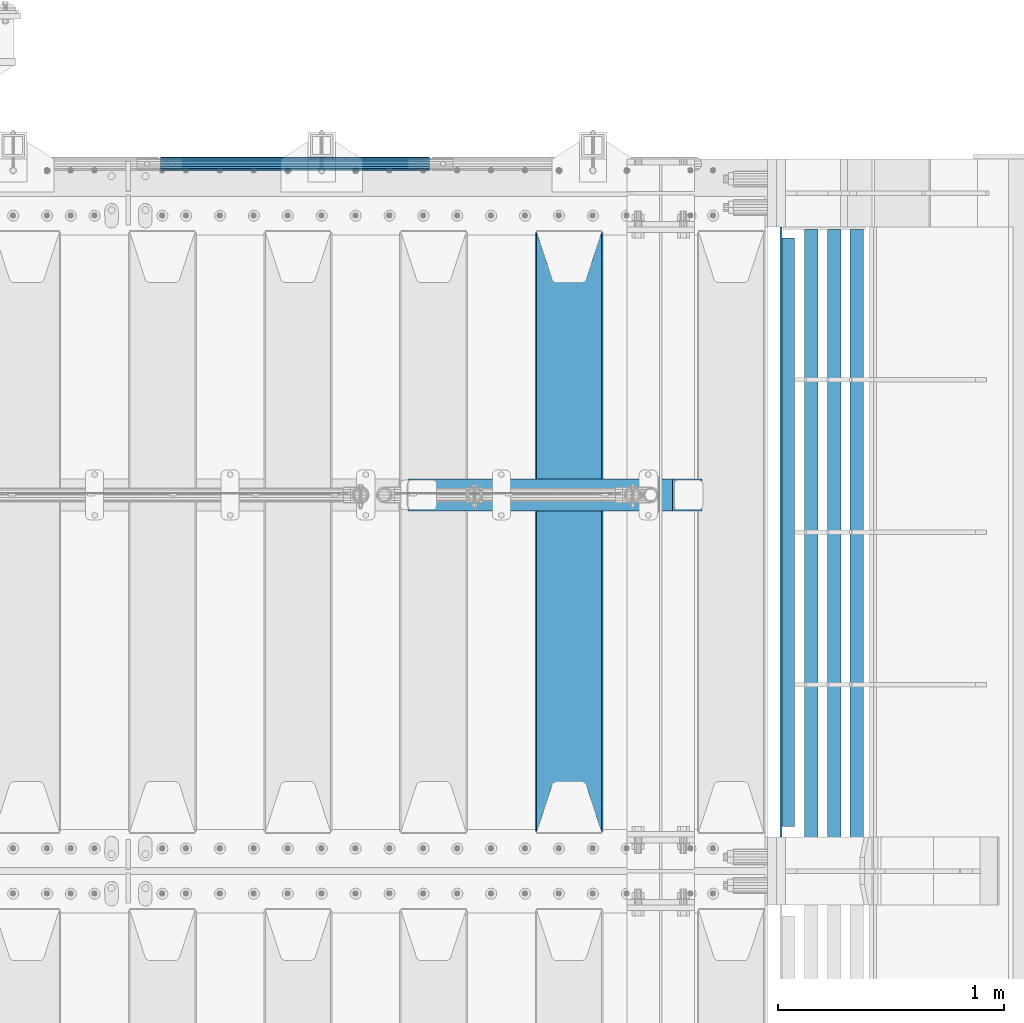
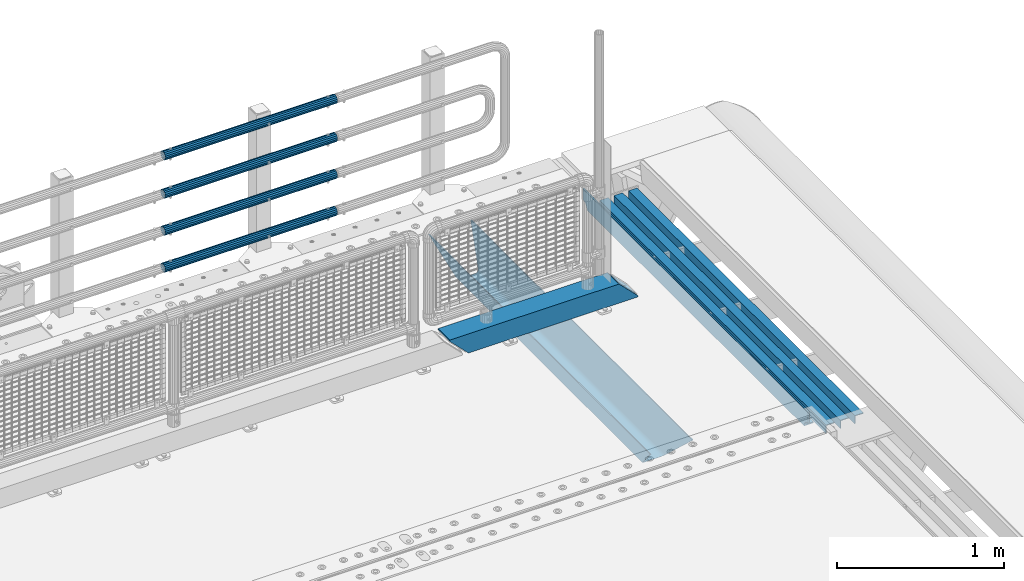
# One storey, part 102 of 193: 10 beams.
"""IFC2X3 building model written with IfcOpenShell, lengths in millimetres."""

from ifc_helpers import new_model, si_unit, frame, origin_with_axes, place, context, subcontext, project, spatial, faceted_brep, material, type_object, element, save


model = new_model("IFC2X3")

# Units and contexts
model_context = context("Model", 3, precision=1e-05, world=origin_with_axes())
body_context = subcontext(model_context, "Body", "Model", "MODEL_VIEW")
ifc_project = project(units=[si_unit("LENGTHUNIT", "METRE", prefix="MILLI"), si_unit("AREAUNIT", "SQUARE_METRE"), si_unit("VOLUMEUNIT", "CUBIC_METRE"), si_unit("MASSUNIT", "GRAM", prefix="KILO"), si_unit("TIMEUNIT", "SECOND"), si_unit("PLANEANGLEUNIT", "RADIAN"), si_unit("SOLIDANGLEUNIT", "STERADIAN"), si_unit("THERMODYNAMICTEMPERATUREUNIT", "DEGREE_CELSIUS"), si_unit("LUMINOUSINTENSITYUNIT", "LUMEN")], contexts=[model_context])

# Site, building, storey
site_placement = place(None, origin_with_axes())
site = spatial("IfcSite", under=ifc_project, at=site_placement, CompositionType="ELEMENT")
building_placement = place(site_placement, origin_with_axes())
building = spatial("IfcBuilding", under=site, at=building_placement, Name="Standard", CompositionType="ELEMENT")
storey_placement = place(building_placement, origin_with_axes())
storey = spatial("IfcBuildingStorey", under=building, at=storey_placement, Name="Undefined", CompositionType="ELEMENT", Elevation=0.0)

# Beams
ifc_material_1 = material(Name="STEEL/S355N")
beam_type_1 = type_object("IfcBeamType", PredefinedType="NOTDEFINED")
beam_1_placement = place(storey_placement, frame((-29300.0, 27175.0, -115.0), z_axis=(0.0, 0.0, 1.0), x_axis=(0.0, 1.0, 0.0)))
element("IfcBeam", 1, at=beam_1_placement, inside=storey, type_object=beam_type_1, material=ifc_material_1, context=body_context, shape_type="Brep", body=[
    faceted_brep([(0.0, 150.0, 115.0), (0.0, 143.689999999999, 115.0), (2650.00000000297, 143.689999999999, 115.0), (2650.00000000297, 150.0, 115.0), (2650.00000000297, 142.059565218398, 110.000000003094), (2650.00000000297, 148.3695652184, 110.000000003094), (2441.90079219209, -80.1103600731112, -98.0992078077845), (2437.7588105432, -77.5672621345584, -102.241189456673), (2434.06523489747, -74.4080125315522, -105.934765102404), (2430.9108609509, -70.710272125576, -109.089139048974), (2428.37322971128, -66.5649389910068, -111.626770288588), (2426.51472138055, -62.0739139532889, -113.485278619323), (2425.38102192092, -57.3475956567672, -114.618978078955), (2424.99999999988, -52.5021667386536, -115.0), (2424.99999999988, 52.5021667386536, -115.0), (2425.38102192092, 57.3475956567672, -114.618978078955), (2426.51472138055, 62.0739139532889, -113.485278619323), (2428.37322971128, 66.5649389910068, -111.626770288588), (2430.9108609509, 70.710272125576, -109.089139048974), (2434.06523489747, 74.4080125315522, -105.934765102404), (2437.7588105432, 77.5672621345584, -102.241189456673), (2441.90079219209, 80.1103600731112, -98.0992078077846), (2446.38936140512, 81.9747917625791, -93.6106385947584), (2448.2494850041, 76.2713538057251, -91.7505149957729), (2444.62967112263, 74.76777986261, -95.3703288772456), (2441.28936334127, 72.7168944282894, -98.710636658607), (2438.31067330439, 70.1691124903846, -101.689326695487), (2435.76682334748, 67.1870637758839, -104.233176652398), (2433.72034654134, 63.8440531834895, -106.279653458539), (2432.22154950042, 60.222258798236, -107.778450499454), (2431.30727574265, 56.4107117849089, -108.692724257221), (2430.99999999987, 52.5031078186876, -109.0), (2430.99999999987, -52.5031078186876, -109.0), (2431.30727574265, -56.4107117849089, -108.692724257221), (2432.22154950042, -60.222258798236, -107.778450499454), (2433.72034654134, -63.8440531834895, -106.279653458539), (2435.76682334748, -67.1870637758839, -104.233176652398), (2438.31067330439, -70.1691124903846, -101.689326695487), (2441.28936334127, -72.7168944282894, -98.7106366586071), (2444.62967112263, -74.76777986261, -95.3703288772457), (2448.2494850041, -76.2713538057251, -91.7505149957729), (2650.00000000297, -142.059565218398, 110.000000003094), (2650.00000000297, -148.3695652184, 110.000000003094), (2446.38936140512, -81.9747917625791, -93.6106385947584), (2650.00000000297, -143.689999999999, 115.0), (2650.00000000297, -150.0, 115.0), (0.0, -143.689999999999, 115.0), (0.0, -150.0, 115.0), (0.0, -148.369565218261, 110.000000002667), (203.610638597427, -81.9747917625791, -93.6106385947584), (208.099207810446, -80.1103600731112, -98.0992078077845), (212.241189459342, -77.5672621345584, -102.241189456673), (215.93476510507, -74.4080125315522, -105.934765102404), (219.089139051641, -70.710272125576, -109.089139048974), (221.626770291256, -66.5649389910068, -111.626770288588), (223.485278621989, -62.0739139532889, -113.485278619323), (224.618978081624, -57.3475956567672, -114.618978078955), (225.000000002663, -52.5021667386536, -115.0), (225.000000002663, 52.5021667386536, -115.0), (224.618978081624, 57.3475956567672, -114.618978078955), (223.485278621989, 62.0739139532889, -113.485278619323), (221.626770291256, 66.5649389910068, -111.626770288588), (219.089139051641, 70.710272125576, -109.089139048974), (215.93476510507, 74.4080125315522, -105.934765102404), (212.241189459342, 77.5672621345584, -102.241189456673), (208.099207810446, 80.1103600731112, -98.0992078077846), (203.610638597427, 81.9747917625791, -93.6106385947584), (0.0, 148.369565218261, 110.000000002667), (0.0, 142.05956521826, 110.000000002667), (201.750514998439, 76.2713538057251, -91.7505149957729), (205.370328879915, 74.76777986261, -95.3703288772456), (208.710636661275, 72.7168944282894, -98.710636658607), (211.689326698157, 70.1691124903846, -101.689326695487), (214.233176655063, 67.1870637758839, -104.233176652398), (216.279653461206, 63.8440531834895, -106.279653458539), (217.778450502123, 60.222258798236, -107.778450499454), (218.69272425989, 56.4107117849089, -108.692724257221), (219.00000000267, 52.5031078186876, -109.0), (219.00000000267, -52.5031078186876, -109.0), (218.69272425989, -56.4107117849089, -108.692724257221), (217.778450502123, -60.222258798236, -107.778450499454), (216.279653461206, -63.8440531834895, -106.279653458539), (214.233176655063, -67.1870637758839, -104.233176652398), (211.689326698157, -70.1691124903846, -101.689326695487), (208.710636661275, -72.7168944282894, -98.7106366586071), (205.370328879915, -74.76777986261, -95.3703288772457), (201.750514998439, -76.2713538057251, -91.7505149957729), (0.0, -142.05956521826, 110.000000002667)], [[[0, 1, 2, 3]], [[3, 2, 4, 5]], [[6, 7, 8, 9, 10, 11, 12, 13, 14, 15, 16, 17, 18, 19, 20, 21, 22, 5, 4, 23, 24, 25, 26, 27, 28, 29, 30, 31, 32, 33, 34, 35, 36, 37, 38, 39, 40, 41, 42, 43]], [[44, 45, 42, 41]], [[46, 47, 45, 44]], [[43, 42, 45, 47, 48, 49]], [[6, 43, 49, 50]], [[7, 6, 50, 51]], [[8, 7, 51, 52]], [[9, 8, 52, 53]], [[10, 9, 53, 54]], [[11, 10, 54, 55]], [[12, 11, 55, 56]], [[13, 12, 56, 57]], [[14, 13, 57, 58]], [[15, 14, 58, 59]], [[16, 15, 59, 60]], [[17, 16, 60, 61]], [[18, 17, 61, 62]], [[19, 18, 62, 63]], [[20, 19, 63, 64]], [[21, 20, 64, 65]], [[22, 21, 65, 66]], [[0, 3, 5, 22, 66, 67]], [[1, 0, 67, 68]], [[23, 4, 2, 1, 68, 69]], [[24, 23, 69, 70]], [[25, 24, 70, 71]], [[26, 25, 71, 72]], [[27, 26, 72, 73]], [[28, 27, 73, 74]], [[29, 28, 74, 75]], [[30, 29, 75, 76]], [[31, 30, 76, 77]], [[32, 31, 77, 78]], [[33, 32, 78, 79]], [[34, 33, 79, 80]], [[35, 34, 80, 81]], [[36, 35, 81, 82]], [[37, 36, 82, 83]], [[38, 37, 83, 84]], [[39, 38, 84, 85]], [[40, 39, 85, 86]], [[46, 44, 41, 40, 86, 87]], [[47, 46, 87, 48]], [[86, 85, 84, 83, 82, 81, 80, 79, 78, 77, 76, 75, 74, 73, 72, 71, 70, 69, 68, 67, 66, 65, 64, 63, 62, 61, 60, 59, 58, 57, 56, 55, 54, 53, 52, 51, 50, 49, 48, 87]]]),
])
ifc_material_2 = material(Name="STEEL/S355J2")
beam_type_2 = type_object("IfcBeamType", PredefinedType="NOTDEFINED")
beam_2_placement = place(storey_placement, frame((-28335.4974739935, 27150.0, -124.999999999993), z_axis=(0.0, 0.0, 1.0), x_axis=(0.0, 1.0, 0.0)))
element("IfcBeam", 2, at=beam_2_placement, inside=storey, type_object=beam_type_2, material=ifc_material_2, context=body_context, shape_type="Brep", body=[
    faceted_brep([(2700.0, 22.5, -15.0), (2684.54915028125, 22.5000000000036, -17.4471741852423), (2684.54915028125, 32.5000000000036, -17.4471741852423), (2700.0, 32.5, -15.0), (2670.61073738538, 22.5000000000036, -24.5491502812526), (2670.61073738538, 32.5000000000036, -24.5491502812526), (2659.54915028125, 22.5000000000036, -35.6107373853764), (2659.54915028125, 32.5000000000036, -35.6107373853764), (2652.44717418524, 22.5000000000036, -49.5491502812526), (2652.44717418524, 32.5000000000036, -49.5491502812526), (2651.58384440325, -32.5, -55.0), (2650.0, -32.5, -65.0), (2650.0, 32.5, -65.0), (2651.58384440325, 22.5, -55.0), (0.0, 32.5, 65.0), (0.0, 22.5, 65.0), (2700.0, 22.5, 65.0), (2700.0, 32.5, 65.0), (0.0, 32.5, -15.0), (0.0, 22.5, -15.0), (15.4508497187489, 32.5, -17.4471741852423), (15.4508497187489, 22.5, -17.4471741852423), (29.3892626146226, 32.5, -24.5491502812526), (29.3892626146226, 22.5, -24.5491502812526), (40.4508497187489, 32.5, -35.6107373853764), (40.4508497187489, 22.5, -35.6107373853764), (47.5528258147569, 32.5, -49.5491502812526), (47.5528258147569, 22.5, -49.5491502812526), (50.0, -32.5, -65.0), (48.4161555967548, -32.5, -55.0), (48.4161555967548, 22.5, -55.0), (50.0, 32.5, -65.0)], [[[0, 1, 2, 3]], [[4, 5, 2, 1]], [[6, 7, 5, 4]], [[8, 9, 7, 6]], [[10, 11, 12, 9, 8, 13]], [[14, 15, 16, 17]], [[15, 14, 18, 19]], [[19, 18, 20, 21]], [[21, 20, 22, 23]], [[23, 22, 24, 25]], [[25, 24, 26, 27]], [[28, 29, 30, 27, 26, 31]], [[30, 29, 10, 13]], [[16, 15, 19, 21, 23, 25, 27, 30, 13, 8, 6, 4, 1, 0]], [[17, 16, 0, 3]], [[5, 7, 9, 12, 31, 26, 24, 22, 20, 18, 14, 17, 3, 2]], [[28, 31, 12, 11]], [[29, 28, 11, 10]]]),
])
beam_type_3 = type_object("IfcBeamType", PredefinedType="NOTDEFINED")
for number, where, z_axis, x_axis in (
    (3, (-28028.001170099, 29839.9999004142, -209.999999999564), (0.0, 0.0, -1.0), (0.0, -1.0, 0.0)),
    (4, (-28128.001170099, 29839.9999004143, -209.999999999564), (0.0, 0.0, -1.0), (0.0, -1.0, 0.0)),
    (5, (-28228.0011700997, 29840.0000023388, -209.999999999622), (0.0, 0.0, -1.0), (0.0, -1.0, 0.0)),
):
    element("IfcBeam", number, at=place(storey_placement, frame(where, z_axis=z_axis, x_axis=x_axis)), inside=storey, type_object=beam_type_3, material=ifc_material_2, context=body_context, shape_type="Brep", body=[
        faceted_brep([(3.63797880709171e-12, 30.0000000000036, -30.0), (0.0, 30.0000000000036, 30.0), (2710.00017042502, 30.0000000000036, 30.0), (2710.00017042501, 30.0000000000036, -30.0), (0.0, 24.0000000000036, 30.0), (2710.00017042502, 24.0000000000036, 30.0), (0.0, 24.0000000000036, -24.0), (2710.00017042502, 24.0000000000036, -24.0), (3.63797880709171e-12, -29.9999999999964, -24.0), (2710.00017042502, -29.9999999999964, -24.0), (3.63797880709171e-12, -29.9999999999964, -30.0), (2710.00017042501, -29.9999999999964, -30.0)], [[[0, 1, 2, 3]], [[1, 4, 5, 2]], [[4, 6, 7, 5]], [[6, 8, 9, 7]], [[8, 10, 11, 9]], [[10, 0, 3, 11]], [[5, 7, 9, 11, 3, 2]], [[10, 8, 6, 4, 1, 0]]]),
    ])
ifc_material_3 = material()
beam_type_4 = type_object("IfcBeamType", PredefinedType="NOTDEFINED")
beam_3_placement = place(storey_placement, frame((-31107.9999999999, 30129.8499999996, 419.849999999748), z_axis=(0.0, -1.0, 0.0), x_axis=(1.0, 0.0, 0.0)))
element("IfcBeam", 6, at=beam_3_placement, inside=storey, type_object=beam_type_4, material=ifc_material_3, context=body_context, shape_type="Brep", body=[
    faceted_brep([(0.0, -26.5499999999993, 0.0), (0.0, -24.5290015881765, 10.1602451292931), (1190.0, -24.5290015881747, 10.1602451292929), (1190.0, -26.55, 0.0), (0.0, -18.7736850405017, 18.7736850405028), (1190.0, -18.7736850405028, 18.7736850405017), (0.0, -10.1602451292929, 24.5290015881747), (1190.0, -10.1602451292931, 24.5290015881765), (0.0, 0.0, 26.55), (1190.0, 0.0, 26.5499999999993), (0.0, 10.1602451292929, 24.5290015881747), (1190.0, 10.1602451292932, 24.5290015881765), (0.0, 18.7736850405017, 18.7736850405028), (1190.0, 18.7736850405029, 18.7736850405017), (0.0, 24.5290015881765, 10.1602451292931), (1190.0, 24.5290015881747, 10.1602451292929), (0.0, 26.5499999999993, 0.0), (1190.0, 26.55, 0.0), (0.0, 24.5290015881765, -10.1602451292931), (1190.0, 24.5290015881747, -10.1602451292929), (0.0, 18.7736850405017, -18.7736850405028), (1190.0, 18.7736850405028, -18.7736850405017), (0.0, 10.1602451292929, -24.5290015881747), (1190.0, 10.1602451292931, -24.5290015881765), (0.0, 0.0, -26.55), (1190.0, 0.0, -26.5499999999993), (0.0, -10.1602451292929, -24.5290015881747), (1190.0, -10.1602451292931, -24.5290015881765), (0.0, -18.7736850405017, -18.7736850405028), (1190.0, -18.7736850405028, -18.7736850405017), (0.0, -24.5290015881765, -10.1602451292931), (1190.0, -24.5290015881747, -10.1602451292929), (0.0, -30.1500000000015, 0.0), (0.0, -27.8549679052157, -11.5379054858058), (1190.0, -27.8549679052153, -11.5379054858058), (1190.0, -30.15, 0.0), (0.0, -21.3192694527752, -21.3192694527752), (1190.0, -21.3192694527744, -21.3192694527752), (0.0, -11.5379054858058, -27.8549679052157), (1190.0, -11.5379054858075, -27.8549679052157), (0.0, 0.0, -30.1500000000015), (1190.0, 0.0, -30.1500000000015), (0.0, 11.5379054858058, -27.8549679052157), (1190.0, 11.5379054858075, -27.8549679052157), (0.0, 21.3192694527752, -21.3192694527752), (1190.0, 21.3192694527744, -21.3192694527752), (0.0, 27.8549679052157, -11.5379054858058), (1190.0, 27.8549679052153, -11.5379054858058), (0.0, 30.1500000000015, 0.0), (1190.0, 30.15, 0.0), (0.0, 27.8549679052157, 11.5379054858058), (1190.0, 27.8549679052153, 11.5379054858058), (0.0, 21.3192694527752, 21.3192694527752), (1190.0, 21.3192694527744, 21.3192694527752), (0.0, 11.5379054858058, 27.8549679052157), (1190.0, 11.5379054858075, 27.8549679052157), (0.0, 0.0, 30.1500000000015), (1190.0, 0.0, 30.1500000000015), (0.0, -11.5379054858058, 27.8549679052157), (1190.0, -11.5379054858075, 27.8549679052157), (0.0, -21.3192694527752, 21.3192694527752), (1190.0, -21.3192694527744, 21.3192694527752), (0.0, -27.8549679052157, 11.5379054858058), (1190.0, -27.8549679052153, 11.5379054858058)], [[[0, 1, 2, 3]], [[1, 4, 5, 2]], [[4, 6, 7, 5]], [[6, 8, 9, 7]], [[8, 10, 11, 9]], [[10, 12, 13, 11]], [[12, 14, 15, 13]], [[14, 16, 17, 15]], [[16, 18, 19, 17]], [[18, 20, 21, 19]], [[20, 22, 23, 21]], [[22, 24, 25, 23]], [[24, 26, 27, 25]], [[26, 28, 29, 27]], [[28, 30, 31, 29]], [[30, 0, 3, 31]], [[32, 33, 34, 35]], [[33, 36, 37, 34]], [[36, 38, 39, 37]], [[38, 40, 41, 39]], [[40, 42, 43, 41]], [[42, 44, 45, 43]], [[44, 46, 47, 45]], [[46, 48, 49, 47]], [[48, 50, 51, 49]], [[50, 52, 53, 51]], [[52, 54, 55, 53]], [[54, 56, 57, 55]], [[56, 58, 59, 57]], [[58, 60, 61, 59]], [[60, 62, 63, 61]], [[62, 32, 35, 63]], [[37, 39, 41, 43, 45, 47, 49, 51, 53, 55, 57, 59, 61, 63, 35, 34], [5, 7, 9, 11, 13, 15, 17, 19, 21, 23, 25, 27, 29, 31, 3, 2]], [[62, 60, 58, 56, 54, 52, 50, 48, 46, 44, 42, 40, 38, 36, 33, 32], [30, 28, 26, 24, 22, 20, 18, 16, 14, 12, 10, 8, 6, 4, 1, 0]]]),
])
beam_4_placement = place(storey_placement, frame((-31107.9999999999, 30129.8499999996, 149.549999999748), z_axis=(0.0, -1.0, 0.0), x_axis=(1.0, 0.0, 0.0)))
element("IfcBeam", 7, at=beam_4_placement, inside=storey, type_object=beam_type_4, material=ifc_material_3, context=body_context, shape_type="Brep", body=[
    faceted_brep([(0.0, -26.5499999999993, 0.0), (0.0, -24.5290015881765, 10.1602451292931), (1190.0, -24.5290015881747, 10.1602451292929), (1190.0, -26.55, 0.0), (0.0, -18.7736850405017, 18.7736850405028), (1190.0, -18.7736850405028, 18.7736850405017), (0.0, -10.1602451292929, 24.5290015881747), (1190.0, -10.1602451292931, 24.5290015881765), (0.0, 0.0, 26.55), (1190.0, 0.0, 26.5499999999993), (0.0, 10.1602451292929, 24.5290015881747), (1190.0, 10.1602451292932, 24.5290015881765), (0.0, 18.7736850405017, 18.7736850405028), (1190.0, 18.7736850405029, 18.7736850405017), (0.0, 24.5290015881765, 10.1602451292931), (1190.0, 24.5290015881747, 10.1602451292929), (0.0, 26.5499999999993, 0.0), (1190.0, 26.55, 0.0), (0.0, 24.5290015881765, -10.1602451292931), (1190.0, 24.5290015881747, -10.1602451292929), (0.0, 18.7736850405017, -18.7736850405028), (1190.0, 18.7736850405028, -18.7736850405017), (0.0, 10.1602451292929, -24.5290015881747), (1190.0, 10.1602451292931, -24.5290015881765), (0.0, 0.0, -26.55), (1190.0, 0.0, -26.5499999999993), (0.0, -10.1602451292929, -24.5290015881747), (1190.0, -10.1602451292931, -24.5290015881765), (0.0, -18.7736850405017, -18.7736850405028), (1190.0, -18.7736850405028, -18.7736850405017), (0.0, -24.5290015881765, -10.1602451292931), (1190.0, -24.5290015881747, -10.1602451292929), (0.0, -30.1500000000015, 0.0), (0.0, -27.8549679052157, -11.5379054858058), (1190.0, -27.8549679052153, -11.5379054858058), (1190.0, -30.15, 0.0), (0.0, -21.3192694527752, -21.3192694527752), (1190.0, -21.3192694527744, -21.3192694527752), (0.0, -11.5379054858058, -27.8549679052157), (1190.0, -11.5379054858075, -27.8549679052157), (0.0, 0.0, -30.1500000000015), (1190.0, 0.0, -30.1500000000015), (0.0, 11.5379054858058, -27.8549679052157), (1190.0, 11.5379054858075, -27.8549679052157), (0.0, 21.3192694527752, -21.3192694527752), (1190.0, 21.3192694527744, -21.3192694527752), (0.0, 27.8549679052157, -11.5379054858058), (1190.0, 27.8549679052153, -11.5379054858058), (0.0, 30.1500000000015, 0.0), (1190.0, 30.15, 0.0), (0.0, 27.8549679052157, 11.5379054858058), (1190.0, 27.8549679052153, 11.5379054858058), (0.0, 21.3192694527752, 21.3192694527752), (1190.0, 21.3192694527744, 21.3192694527752), (0.0, 11.5379054858058, 27.8549679052157), (1190.0, 11.5379054858075, 27.8549679052157), (0.0, 0.0, 30.1500000000015), (1190.0, 0.0, 30.1500000000015), (0.0, -11.5379054858058, 27.8549679052157), (1190.0, -11.5379054858075, 27.8549679052157), (0.0, -21.3192694527752, 21.3192694527752), (1190.0, -21.3192694527744, 21.3192694527752), (0.0, -27.8549679052157, 11.5379054858058), (1190.0, -27.8549679052153, 11.5379054858058)], [[[0, 1, 2, 3]], [[1, 4, 5, 2]], [[4, 6, 7, 5]], [[6, 8, 9, 7]], [[8, 10, 11, 9]], [[10, 12, 13, 11]], [[12, 14, 15, 13]], [[14, 16, 17, 15]], [[16, 18, 19, 17]], [[18, 20, 21, 19]], [[20, 22, 23, 21]], [[22, 24, 25, 23]], [[24, 26, 27, 25]], [[26, 28, 29, 27]], [[28, 30, 31, 29]], [[30, 0, 3, 31]], [[32, 33, 34, 35]], [[33, 36, 37, 34]], [[36, 38, 39, 37]], [[38, 40, 41, 39]], [[40, 42, 43, 41]], [[42, 44, 45, 43]], [[44, 46, 47, 45]], [[46, 48, 49, 47]], [[48, 50, 51, 49]], [[50, 52, 53, 51]], [[52, 54, 55, 53]], [[54, 56, 57, 55]], [[56, 58, 59, 57]], [[58, 60, 61, 59]], [[60, 62, 63, 61]], [[62, 32, 35, 63]], [[37, 39, 41, 43, 45, 47, 49, 51, 53, 55, 57, 59, 61, 63, 35, 34], [5, 7, 9, 11, 13, 15, 17, 19, 21, 23, 25, 27, 29, 31, 3, 2]], [[62, 60, 58, 56, 54, 52, 50, 48, 46, 44, 42, 40, 38, 36, 33, 32], [30, 28, 26, 24, 22, 20, 18, 16, 14, 12, 10, 8, 6, 4, 1, 0]]]),
])
beam_5_placement = place(storey_placement, frame((-31107.9999999999, 30129.8499999996, 969.549999999748), z_axis=(0.0, -1.0, 0.0), x_axis=(1.0, 0.0, 0.0)))
element("IfcBeam", 8, at=beam_5_placement, inside=storey, type_object=beam_type_4, material=ifc_material_3, context=body_context, shape_type="Brep", body=[
    faceted_brep([(0.0, -26.5499999999993, 0.0), (0.0, -24.5290015881765, 10.1602451292931), (1190.0, -24.5290015881747, 10.1602451292929), (1190.0, -26.55, 0.0), (0.0, -18.7736850405017, 18.7736850405028), (1190.0, -18.7736850405028, 18.7736850405017), (0.0, -10.1602451292929, 24.5290015881747), (1190.0, -10.1602451292931, 24.5290015881765), (0.0, 0.0, 26.55), (1190.0, 0.0, 26.5499999999993), (0.0, 10.1602451292929, 24.5290015881747), (1190.0, 10.1602451292932, 24.5290015881765), (0.0, 18.7736850405017, 18.7736850405028), (1190.0, 18.7736850405029, 18.7736850405017), (0.0, 24.5290015881765, 10.1602451292931), (1190.0, 24.5290015881747, 10.1602451292929), (0.0, 26.5499999999993, 0.0), (1190.0, 26.55, 0.0), (0.0, 24.5290015881765, -10.1602451292931), (1190.0, 24.5290015881747, -10.1602451292929), (0.0, 18.7736850405017, -18.7736850405028), (1190.0, 18.7736850405028, -18.7736850405017), (0.0, 10.1602451292929, -24.5290015881747), (1190.0, 10.1602451292931, -24.5290015881765), (0.0, 0.0, -26.55), (1190.0, 0.0, -26.5499999999993), (0.0, -10.1602451292929, -24.5290015881747), (1190.0, -10.1602451292931, -24.5290015881765), (0.0, -18.7736850405017, -18.7736850405028), (1190.0, -18.7736850405028, -18.7736850405017), (0.0, -24.5290015881765, -10.1602451292931), (1190.0, -24.5290015881747, -10.1602451292929), (0.0, -30.1500000000015, 0.0), (0.0, -27.8549679052157, -11.5379054858058), (1190.0, -27.8549679052153, -11.5379054858058), (1190.0, -30.15, 0.0), (0.0, -21.3192694527752, -21.3192694527752), (1190.0, -21.3192694527744, -21.3192694527752), (0.0, -11.5379054858058, -27.8549679052157), (1190.0, -11.5379054858075, -27.8549679052157), (0.0, 0.0, -30.1500000000015), (1190.0, 0.0, -30.1500000000015), (0.0, 11.5379054858058, -27.8549679052157), (1190.0, 11.5379054858075, -27.8549679052157), (0.0, 21.3192694527752, -21.3192694527752), (1190.0, 21.3192694527744, -21.3192694527752), (0.0, 27.8549679052157, -11.5379054858058), (1190.0, 27.8549679052153, -11.5379054858058), (0.0, 30.1500000000015, 0.0), (1190.0, 30.15, 0.0), (0.0, 27.8549679052157, 11.5379054858058), (1190.0, 27.8549679052153, 11.5379054858058), (0.0, 21.3192694527752, 21.3192694527752), (1190.0, 21.3192694527744, 21.3192694527752), (0.0, 11.5379054858058, 27.8549679052157), (1190.0, 11.5379054858075, 27.8549679052157), (0.0, 0.0, 30.1500000000015), (1190.0, 0.0, 30.1500000000015), (0.0, -11.5379054858058, 27.8549679052157), (1190.0, -11.5379054858075, 27.8549679052157), (0.0, -21.3192694527752, 21.3192694527752), (1190.0, -21.3192694527744, 21.3192694527752), (0.0, -27.8549679052157, 11.5379054858058), (1190.0, -27.8549679052153, 11.5379054858058)], [[[0, 1, 2, 3]], [[1, 4, 5, 2]], [[4, 6, 7, 5]], [[6, 8, 9, 7]], [[8, 10, 11, 9]], [[10, 12, 13, 11]], [[12, 14, 15, 13]], [[14, 16, 17, 15]], [[16, 18, 19, 17]], [[18, 20, 21, 19]], [[20, 22, 23, 21]], [[22, 24, 25, 23]], [[24, 26, 27, 25]], [[26, 28, 29, 27]], [[28, 30, 31, 29]], [[30, 0, 3, 31]], [[32, 33, 34, 35]], [[33, 36, 37, 34]], [[36, 38, 39, 37]], [[38, 40, 41, 39]], [[40, 42, 43, 41]], [[42, 44, 45, 43]], [[44, 46, 47, 45]], [[46, 48, 49, 47]], [[48, 50, 51, 49]], [[50, 52, 53, 51]], [[52, 54, 55, 53]], [[54, 56, 57, 55]], [[56, 58, 59, 57]], [[58, 60, 61, 59]], [[60, 62, 63, 61]], [[62, 32, 35, 63]], [[37, 39, 41, 43, 45, 47, 49, 51, 53, 55, 57, 59, 61, 63, 35, 34], [5, 7, 9, 11, 13, 15, 17, 19, 21, 23, 25, 27, 29, 31, 3, 2]], [[62, 60, 58, 56, 54, 52, 50, 48, 46, 44, 42, 40, 38, 36, 33, 32], [30, 28, 26, 24, 22, 20, 18, 16, 14, 12, 10, 8, 6, 4, 1, 0]]]),
])
beam_6_placement = place(storey_placement, frame((-31107.9999999999, 30129.8499999996, 689.549999999748), z_axis=(0.0, -1.0, 0.0), x_axis=(1.0, 0.0, 0.0)))
element("IfcBeam", 9, at=beam_6_placement, inside=storey, type_object=beam_type_4, material=ifc_material_3, context=body_context, shape_type="Brep", body=[
    faceted_brep([(0.0, -26.5499999999993, 0.0), (0.0, -24.5290015881765, 10.1602451292931), (1190.0, -24.5290015881747, 10.1602451292929), (1190.0, -26.55, 0.0), (0.0, -18.7736850405017, 18.7736850405028), (1190.0, -18.7736850405028, 18.7736850405017), (0.0, -10.1602451292929, 24.5290015881747), (1190.0, -10.1602451292931, 24.5290015881765), (0.0, 0.0, 26.55), (1190.0, 0.0, 26.5499999999993), (0.0, 10.1602451292929, 24.5290015881747), (1190.0, 10.1602451292932, 24.5290015881765), (0.0, 18.7736850405017, 18.7736850405028), (1190.0, 18.7736850405029, 18.7736850405017), (0.0, 24.5290015881765, 10.1602451292931), (1190.0, 24.5290015881747, 10.1602451292929), (0.0, 26.5499999999993, 0.0), (1190.0, 26.55, 0.0), (0.0, 24.5290015881765, -10.1602451292931), (1190.0, 24.5290015881747, -10.1602451292929), (0.0, 18.7736850405017, -18.7736850405028), (1190.0, 18.7736850405028, -18.7736850405017), (0.0, 10.1602451292929, -24.5290015881747), (1190.0, 10.1602451292931, -24.5290015881765), (0.0, 0.0, -26.55), (1190.0, 0.0, -26.5499999999993), (0.0, -10.1602451292929, -24.5290015881747), (1190.0, -10.1602451292931, -24.5290015881765), (0.0, -18.7736850405017, -18.7736850405028), (1190.0, -18.7736850405028, -18.7736850405017), (0.0, -24.5290015881765, -10.1602451292931), (1190.0, -24.5290015881747, -10.1602451292929), (0.0, -30.1500000000015, 0.0), (0.0, -27.8549679052157, -11.5379054858058), (1190.0, -27.8549679052153, -11.5379054858058), (1190.0, -30.15, 0.0), (0.0, -21.3192694527752, -21.3192694527752), (1190.0, -21.3192694527744, -21.3192694527752), (0.0, -11.5379054858058, -27.8549679052157), (1190.0, -11.5379054858075, -27.8549679052157), (0.0, 0.0, -30.1500000000015), (1190.0, 0.0, -30.1500000000015), (0.0, 11.5379054858058, -27.8549679052157), (1190.0, 11.5379054858075, -27.8549679052157), (0.0, 21.3192694527752, -21.3192694527752), (1190.0, 21.3192694527744, -21.3192694527752), (0.0, 27.8549679052157, -11.5379054858058), (1190.0, 27.8549679052153, -11.5379054858058), (0.0, 30.1500000000015, 0.0), (1190.0, 30.15, 0.0), (0.0, 27.8549679052157, 11.5379054858058), (1190.0, 27.8549679052153, 11.5379054858058), (0.0, 21.3192694527752, 21.3192694527752), (1190.0, 21.3192694527744, 21.3192694527752), (0.0, 11.5379054858058, 27.8549679052157), (1190.0, 11.5379054858075, 27.8549679052157), (0.0, 0.0, 30.1500000000015), (1190.0, 0.0, 30.1500000000015), (0.0, -11.5379054858058, 27.8549679052157), (1190.0, -11.5379054858075, 27.8549679052157), (0.0, -21.3192694527752, 21.3192694527752), (1190.0, -21.3192694527744, 21.3192694527752), (0.0, -27.8549679052157, 11.5379054858058), (1190.0, -27.8549679052153, 11.5379054858058)], [[[0, 1, 2, 3]], [[1, 4, 5, 2]], [[4, 6, 7, 5]], [[6, 8, 9, 7]], [[8, 10, 11, 9]], [[10, 12, 13, 11]], [[12, 14, 15, 13]], [[14, 16, 17, 15]], [[16, 18, 19, 17]], [[18, 20, 21, 19]], [[20, 22, 23, 21]], [[22, 24, 25, 23]], [[24, 26, 27, 25]], [[26, 28, 29, 27]], [[28, 30, 31, 29]], [[30, 0, 3, 31]], [[32, 33, 34, 35]], [[33, 36, 37, 34]], [[36, 38, 39, 37]], [[38, 40, 41, 39]], [[40, 42, 43, 41]], [[42, 44, 45, 43]], [[44, 46, 47, 45]], [[46, 48, 49, 47]], [[48, 50, 51, 49]], [[50, 52, 53, 51]], [[52, 54, 55, 53]], [[54, 56, 57, 55]], [[56, 58, 59, 57]], [[58, 60, 61, 59]], [[60, 62, 63, 61]], [[62, 32, 35, 63]], [[37, 39, 41, 43, 45, 47, 49, 51, 53, 55, 57, 59, 61, 63, 35, 34], [5, 7, 9, 11, 13, 15, 17, 19, 21, 23, 25, 27, 29, 31, 3, 2]], [[62, 60, 58, 56, 54, 52, 50, 48, 46, 44, 42, 40, 38, 36, 33, 32], [30, 28, 26, 24, 22, 20, 18, 16, 14, 12, 10, 8, 6, 4, 1, 0]]]),
])
beam_type_5 = type_object("IfcBeamType", PredefinedType="NOTDEFINED")
beam_7_placement = place(storey_placement, frame((-30013.0, 28664.5, 98.0199999999977), z_axis=(0.0, 0.0, 1.0), x_axis=(1.0, 0.0, 0.0)))
element("IfcBeam", 10, at=beam_7_placement, inside=storey, type_object=beam_type_5, material=ifc_material_3, context=body_context, shape_type="Brep", body=[
    faceted_brep([(0.0, 70.0, 70.0), (0.0, -70.0, 70.0), (1170.88846984782, -70.0, 70.0), (1170.88846984782, 70.0, 70.0), (1301.0, -60.0, -60.0), (1301.0, 60.0, -60.0), (119.989831466439, 60.0, -60.0), (119.989910626173, -60.0, -60.0), (1180.89643628727, -60.0, 60.0), (2.49929144047201e-09, -60.0, 60.0), (2.49929144047201e-09, 60.0000000000036, 60.0), (1180.89643628727, 60.0, 60.0), (1301.0, -70.0, -60.0079600980746), (1301.0, 70.0, -60.0079600980746), (1301.0, -70.0, -70.0), (1301.0, 70.0, -70.0), (129.999907566686, 70.0, -70.0), (0.0, 70.0, 59.8689646261584), (0.0, -70.0, 59.8690568861577), (129.99999991971, -70.0, -70.0)], [[[0, 1, 2, 3]], [[4, 5, 6, 7]], [[8, 4, 7, 9]], [[9, 10, 11, 8]], [[5, 11, 10, 6]], [[2, 12, 4, 8, 11, 5, 13, 3]], [[4, 12, 14, 15, 13, 5]], [[0, 3, 13, 15, 16, 17]], [[9, 18, 1, 0, 17, 10]], [[14, 12, 2, 1, 18, 19]], [[15, 14, 19, 16]], [[18, 9, 7, 6, 10, 17, 16, 19]]]),
])

save(model, "model.ifc")
